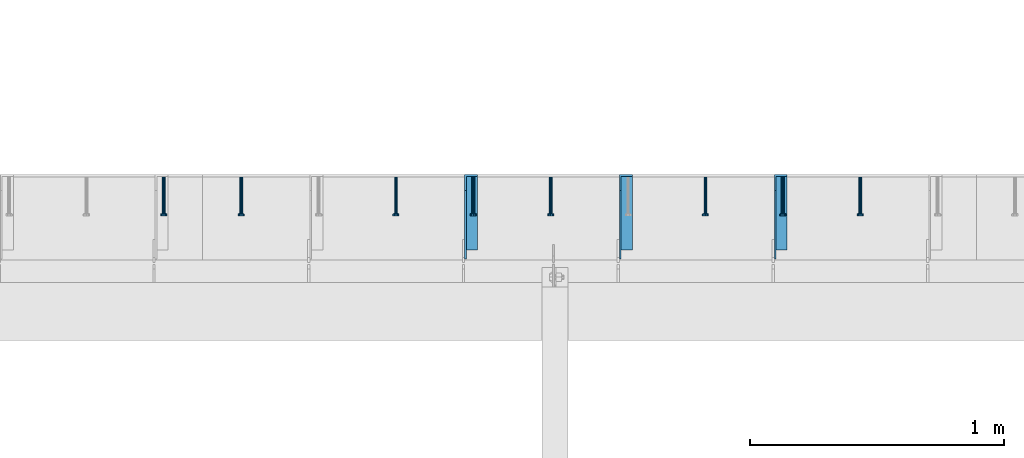
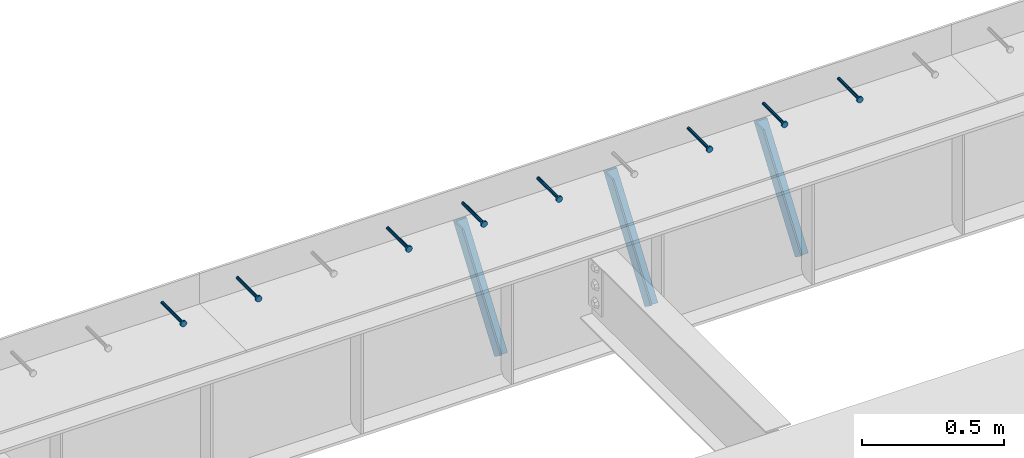
# One storey, part 1339 of 1763: 8 beams, 3 members, 9 elements without a shape of their own.
"""IFC2X3 building model written with IfcOpenShell, lengths in millimetres."""

import ifcopenshell
import ifcopenshell.guid

model = None  # the IFC model being written
_history = None  # IfcOwnerHistory: only IFC2X3 demands one
_inside = {}  # id of a spatial element -> (the spatial element, [elements in it])
_under = {}  # id of a project, library or spatial element -> (it, [spatial elements below it])
_declared = {}  # id of a project -> (the project, [libraries it declares])
_typed = {}  # id of a type object -> (the type object, [elements of that type])
_made_of = {}  # id of a material, layer set ... -> (it, [elements and type objects made of it])


def new_model(schema):
    """Start an empty IFC model of exactly this schema.

    Asked for "IFC4X3", IfcOpenShell would pick the latest addendum, in which some entities
    have other attributes; the version numbers below select the first issue.
    IFC2X3 requires an IfcOwnerHistory on every rooted entity: one is made here for all.
    """
    global model, _history
    if schema == "IFC4X3":
        model = ifcopenshell.file(schema_version=(4, 3, 0, 0))
    else:
        model = ifcopenshell.file(schema=schema)
    _inside.clear()
    _under.clear()
    _declared.clear()
    _typed.clear()
    _made_of.clear()
    _history = None
    if model.schema == "IFC2X3":
        org = make("IfcOrganization", Name="unknown")
        user = make(
            "IfcPersonAndOrganization",
            ThePerson=make("IfcPerson", FamilyName="unknown"),
            TheOrganization=org,
        )
        app = make(
            "IfcApplication",
            ApplicationDeveloper=org,
            Version="unknown",
            ApplicationFullName="unknown",
            ApplicationIdentifier="unknown",
        )
        _history = make(
            "IfcOwnerHistory",
            OwningUser=user,
            OwningApplication=app,
            ChangeAction="ADDED",
            CreationDate=0,
        )
    return model


def make(cls, **values):
    """One entity of the class cls with the attributes given. An attribute that is None is left unset."""
    return model.create_entity(
        cls, **{name: value for name, value in values.items() if value is not None}
    )


def rooted(cls, **values):
    """An entity with a GlobalId (a new one), such as an element, a storey or a relation."""
    return make(cls, GlobalId=ifcopenshell.guid.new(), OwnerHistory=_history, **values)


def si_unit(unit_type, name, prefix=None):
    """IfcSIUnit, for example si_unit("LENGTHUNIT", "METRE", prefix="MILLI")."""
    return make("IfcSIUnit", UnitType=unit_type, Prefix=prefix, Name=name)


def assignment(units):
    """IfcUnitAssignment: the units of a project."""
    return None if units is None else make("IfcUnitAssignment", Units=units)


def point(xyz):
    """IfcCartesianPoint."""
    return None if xyz is None else make("IfcCartesianPoint", Coordinates=xyz)


def direction(xyz):
    """IfcDirection."""
    return None if xyz is None else make("IfcDirection", DirectionRatios=xyz)


def frame(location, z_axis=None, x_axis=None):
    """IfcAxis2Placement3D, a coordinate frame: its origin and axes. An axis left out is left unset."""
    return make(
        "IfcAxis2Placement3D",
        Location=point(location),
        Axis=direction(z_axis),
        RefDirection=direction(x_axis),
    )


def origin_with_axes():
    """The frame at (0, 0, 0) with the z axis (0, 0, 1) and the x axis (1, 0, 0) written out."""
    return frame((0.0, 0.0, 0.0), z_axis=(0.0, 0.0, 1.0), x_axis=(1.0, 0.0, 0.0))


def place(relative_to, where):
    """IfcLocalPlacement: puts the frame where relative to a parent placement (None: the world)."""
    return make(
        "IfcLocalPlacement", PlacementRelTo=relative_to, RelativePlacement=where
    )


def context(
    kind, dimensions, precision=None, world=None, true_north=None, identifier=None
):
    """IfcGeometricRepresentationContext, for example the 3D "Model" context."""
    return make(
        "IfcGeometricRepresentationContext",
        ContextIdentifier=identifier,
        ContextType=kind,
        CoordinateSpaceDimension=dimensions,
        Precision=precision,
        WorldCoordinateSystem=world,
        TrueNorth=true_north,
    )


def subcontext(parent, identifier, kind, view, scale=None):
    """IfcGeometricRepresentationSubContext, for example "Body" below "Model"."""
    return make(
        "IfcGeometricRepresentationSubContext",
        ContextIdentifier=identifier,
        ContextType=kind,
        ParentContext=parent,
        TargetScale=scale,
        TargetView=view,
    )


def project(units=None, contexts=None):
    """IfcProject with its units and contexts."""
    return rooted(
        "IfcProject",
        Name="project",
        RepresentationContexts=contexts,
        UnitsInContext=assignment(units),
    )


def spatial(cls, under=None, at=None, **own):
    """A site, building, storey or space (cls), placed at a placement, below another one or the project."""
    s = rooted(cls, ObjectPlacement=at, **own)
    if under is not None:
        _under.setdefault(under.id(), (under, []))[1].append(s)
    return s


def faces_of(points, faces, orient=None, outer=None):
    """IfcFace entities. A face is a list of loops; a loop is a list of indices into points, from 0.

    orient and outer hold one flag for each loop. By default every Orientation is true, the
    first loop of a face is its IfcFaceOuterBound and the others are IfcFaceBound.
    """
    made = []
    for i, loops in enumerate(faces):
        bounds = []
        for j, loop in enumerate(loops):
            is_outer = j == 0 if outer is None else outer[i][j]
            bounds.append(
                make(
                    "IfcFaceOuterBound" if is_outer else "IfcFaceBound",
                    Bound=make("IfcPolyLoop", Polygon=[points[k] for k in loop]),
                    Orientation=True if orient is None else orient[i][j],
                )
            )
        made.append(make("IfcFace", Bounds=bounds))
    return made


def faceted_brep(points, faces, orient=None, outer=None, voids=None):
    """IfcFacetedBrep: a solid bounded by flat faces; with voids (closed shells), ...WithVoids."""
    shared = [point(p) for p in points]
    hull = make("IfcClosedShell", CfsFaces=faces_of(shared, faces, orient, outer))
    if voids is None:
        return make("IfcFacetedBrep", Outer=hull)
    return make(
        "IfcFacetedBrepWithVoids",
        Outer=hull,
        Voids=[
            make(cls, CfsFaces=faces_of(shared, fs, o, b)) for cls, fs, o, b in voids
        ],
    )


def shape(context_of_items, identifier, shape_type, items):
    """IfcShapeRepresentation: the items that make up one representation, for example the "Body"."""
    return make(
        "IfcShapeRepresentation",
        ContextOfItems=context_of_items,
        RepresentationIdentifier=identifier,
        RepresentationType=shape_type,
        Items=items,
    )


def material(Name=None, Category=None):
    """IfcMaterial."""
    return make("IfcMaterial", Name=Name, Category=Category)


def made_of(thing, what):
    """Note that an element or type object is made of a material, layer set ...; save() writes the relation."""
    if what is not None:
        _made_of.setdefault(what.id(), (what, []))[1].append(thing)
    return thing


def type_object(cls, material=None, **own):
    """A type object (cls), such as IfcWallType, which elements share."""
    return made_of(rooted(cls, **own), material)


def element(
    cls,
    number,
    at=None,
    inside=None,
    cuts=None,
    type_object=None,
    material=None,
    context=None,
    identifier="Body",
    shape_type=None,
    held_by="IfcProductDefinitionShape",
    body=None,
    shapes=None,
    **own,
):
    """One element of the class cls, such as IfcWall. Its Tag is "e" and its number.

    at: its placement. inside: the storey or other place that contains it. cuts: it is an
    opening in that element (IfcRelVoidsElement). A single representation is given by context,
    identifier, shape_type and body (its items); several are given by shapes. held_by: the class
    of the entity that holds the representations. save() writes the other relations.
    """
    e = rooted(cls, Tag="e%d" % number, ObjectPlacement=at, **own)
    if body is not None:
        shapes = [shape(context, identifier, shape_type, body)]
    if shapes is not None:
        e.Representation = make(held_by, Representations=shapes)
    if inside is not None:
        _inside.setdefault(inside.id(), (inside, []))[1].append(e)
    if cuts is not None:
        rooted(
            "IfcRelVoidsElement", RelatingBuildingElement=cuts, RelatedOpeningElement=e
        )
    if type_object is not None:
        _typed.setdefault(type_object.id(), (type_object, []))[1].append(e)
    return made_of(e, material)


def aggregate(whole, parts):
    """IfcRelAggregates: a whole, such as a stair, and the parts it consists of."""
    return rooted("IfcRelAggregates", RelatingObject=whole, RelatedObjects=parts)


def save(model, path):
    """Write the relations noted so far, then the file.

    IfcRelAggregates (storeys below a building ...), IfcRelContainedInSpatialStructure (elements
    in a storey), IfcRelDefinesByType, IfcRelAssociatesMaterial and IfcRelDeclares: one each for
    every whole, place, type object, material and project.
    """
    for whole, parts in _under.values():
        aggregate(whole, parts)
    for where, things in _inside.values():
        rooted(
            "IfcRelContainedInSpatialStructure",
            RelatedElements=things,
            RelatingStructure=where,
        )
    for kind, things in _typed.values():
        rooted("IfcRelDefinesByType", RelatedObjects=things, RelatingType=kind)
    for what, things in _made_of.values():
        rooted("IfcRelAssociatesMaterial", RelatedObjects=things, RelatingMaterial=what)
    for by, libraries in _declared.values():
        rooted("IfcRelDeclares", RelatingContext=by, RelatedDefinitions=libraries)
    model.write(path)


model = new_model("IFC2X3")

# Units and contexts
model_context = context("Model", 3, precision=1e-05, world=origin_with_axes())
body_context = subcontext(model_context, "Body", "Model", "MODEL_VIEW")
ifc_project = project(units=[si_unit("LENGTHUNIT", "METRE", prefix="MILLI"), si_unit("AREAUNIT", "SQUARE_METRE"), si_unit("VOLUMEUNIT", "CUBIC_METRE"), si_unit("MASSUNIT", "GRAM", prefix="KILO"), si_unit("TIMEUNIT", "SECOND"), si_unit("PLANEANGLEUNIT", "RADIAN"), si_unit("SOLIDANGLEUNIT", "STERADIAN"), si_unit("THERMODYNAMICTEMPERATUREUNIT", "DEGREE_CELSIUS"), si_unit("LUMINOUSINTENSITYUNIT", "LUMEN")], contexts=[model_context])

# Site, building, storey
site_placement = place(None, origin_with_axes())
site = spatial("IfcSite", under=ifc_project, at=site_placement, CompositionType="ELEMENT")
building_placement = place(site_placement, origin_with_axes())
building = spatial("IfcBuilding", under=site, at=building_placement, Name="Undefined", CompositionType="ELEMENT")
storey_placement = place(building_placement, origin_with_axes())
storey = spatial("IfcBuildingStorey", under=building, at=storey_placement, Name="Undefined", CompositionType="ELEMENT", Elevation=0.0)

# Assembly, beam
assembly_1_placement = place(storey_placement, origin_with_axes())
assembly_1 = element("IfcElementAssembly", 1, at=assembly_1_placement, inside=storey, Name="HEADED STUD ANCHOR", AssemblyPlace="NOTDEFINED", PredefinedType="RIGID_FRAME")
ifc_material_1 = material(Name="STEEL/A108")
beam_type = type_object("IfcBeamType", PredefinedType="NOTDEFINED")
beam_1_placement = place(assembly_1_placement, frame((-76250.2372736984, 53984.5250183106, 5264.23140606069), z_axis=(0.0, 0.0, 1.0), x_axis=(0.0, -1.0, 0.0)))
beam_1 = element("IfcBeam", 2, at=beam_1_placement, type_object=beam_type, material=ifc_material_1, Name="HEADED STUD ANCHOR", context=body_context, shape_type="Brep", body=[
    faceted_brep([(0.0, -3.1800000667572, 5.5), (0.0, -5.5, 3.1800000667572), (141.732000000002, -5.5, 3.1800000667572), (141.732000000002, -3.1800000667572, 5.5), (0.0, -6.34999999999491, 1.45519152283669e-11), (141.732000000002, -6.34999990463257, 0.0), (0.0, -5.5, -3.1800000667572), (141.732000000002, -5.5, -3.1800000667572), (0.0, -3.1800000667572, -5.5), (141.732000000002, -3.1800000667572, -5.5), (0.0, 0.0, -6.34999990463257), (141.732000000002, 0.0, -6.34999990463257), (0.0, 3.1800000667572, -5.5), (141.732000000002, 3.1800000667572, -5.5), (0.0, 5.5, -3.1800000667572), (141.732000000002, 5.5, -3.1800000667572), (0.0, 6.34999999999491, -2.91038304567337e-11), (141.732000000002, 6.34999990463257, 0.0), (0.0, 5.5, 3.1800000667572), (141.732000000002, 5.5, 3.1800000667572), (0.0, 3.1800000667572, 5.5), (141.732000000002, 3.1800000667572, 5.5), (0.0, 0.0, 6.34999990463257), (141.732000000002, 0.0, 6.34999990463257), (144.780000000001, -10.9899997711182, 6.34999990463257), (144.780000000001, -6.34000015258789, 10.9899997711182), (144.780000000001, -12.6999998092651, 0.0), (144.780000000001, -10.9899997711182, -6.34999990463257), (144.780000000001, -6.34000015258789, -10.9899997711182), (144.780000000001, 0.0, -12.6899995803833), (144.780000000001, 6.34000015258789, -10.9899997711182), (144.780000000001, 10.9899997711182, -6.34999990463257), (144.780000000001, 12.6999998092651, 0.0), (144.780000000001, 10.9899997711182, 6.34999990463257), (144.780000000001, 6.34000015258789, 10.9899997711182), (144.780000000001, 0.0, 12.6899995803833), (152.400000000001, -10.9899997711182, 6.34999990463257), (152.400000000001, -6.34000015258789, 10.9899997711182), (152.400000000001, -12.6999998092651, 0.0), (152.400000000001, -10.9899997711182, -6.34999990463257), (152.400000000001, -6.34000015258789, -10.9899997711182), (152.400000000001, 0.0, -12.6899995803833), (152.400000000001, 6.34000015258789, -10.9899997711182), (152.400000000001, 10.9899997711182, -6.34999990463257), (152.400000000001, 12.6999998092651, 0.0), (152.400000000001, 10.9899997711182, 6.34999990463257), (152.400000000001, 6.34000015258789, 10.9899997711182), (152.400000000001, 0.0, 12.6899995803833)], [[[0, 1, 2, 3]], [[1, 4, 5, 2]], [[4, 6, 7, 5]], [[6, 8, 9, 7]], [[8, 10, 11, 9]], [[10, 12, 13, 11]], [[12, 14, 15, 13]], [[14, 16, 17, 15]], [[16, 18, 19, 17]], [[18, 20, 21, 19]], [[20, 22, 23, 21]], [[22, 0, 3, 23]], [[22, 20, 18, 16, 14, 12, 10, 8, 6, 4, 1, 0]], [[3, 2, 24, 25]], [[2, 5, 26, 24]], [[5, 7, 27, 26]], [[7, 9, 28, 27]], [[9, 11, 29, 28]], [[11, 13, 30, 29]], [[13, 15, 31, 30]], [[15, 17, 32, 31]], [[17, 19, 33, 32]], [[19, 21, 34, 33]], [[21, 23, 35, 34]], [[23, 3, 25, 35]], [[25, 24, 36, 37]], [[24, 26, 38, 36]], [[26, 27, 39, 38]], [[27, 28, 40, 39]], [[28, 29, 41, 40]], [[29, 30, 42, 41]], [[30, 31, 43, 42]], [[31, 32, 44, 43]], [[32, 33, 45, 44]], [[33, 34, 46, 45]], [[34, 35, 47, 46]], [[35, 25, 37, 47]], [[38, 39, 40, 41, 42, 43, 44, 45, 46, 47, 37, 36]]]),
])
aggregate(assembly_1, [beam_1])

assembly_2_placement = place(storey_placement, origin_with_axes())
assembly_2 = element("IfcElementAssembly", 3, at=assembly_2_placement, inside=storey, Name="HEADED STUD ANCHOR", AssemblyPlace="NOTDEFINED", PredefinedType="RIGID_FRAME")
beam_2_placement = place(assembly_2_placement, frame((-76555.0372736983, 53984.5250183106, 5264.23140606069), z_axis=(0.0, 0.0, 1.0), x_axis=(0.0, -1.0, 0.0)))
beam_2 = element("IfcBeam", 4, at=beam_2_placement, type_object=beam_type, material=ifc_material_1, Name="HEADED STUD ANCHOR", context=body_context, shape_type="Brep", body=[
    faceted_brep([(0.0, -3.1800000667572, 5.5), (0.0, -5.5, 3.1800000667572), (141.732000000002, -5.5, 3.1800000667572), (141.732000000002, -3.1800000667572, 5.5), (0.0, -6.34999999999491, 1.45519152283669e-11), (141.732000000002, -6.34999990463257, 0.0), (0.0, -5.5, -3.1800000667572), (141.732000000002, -5.5, -3.1800000667572), (0.0, -3.1800000667572, -5.5), (141.732000000002, -3.1800000667572, -5.5), (0.0, 0.0, -6.34999990463257), (141.732000000002, 0.0, -6.34999990463257), (0.0, 3.1800000667572, -5.5), (141.732000000002, 3.1800000667572, -5.5), (0.0, 5.5, -3.1800000667572), (141.732000000002, 5.5, -3.1800000667572), (0.0, 6.34999999999491, -2.91038304567337e-11), (141.732000000002, 6.34999990463257, 0.0), (0.0, 5.5, 3.1800000667572), (141.732000000002, 5.5, 3.1800000667572), (0.0, 3.1800000667572, 5.5), (141.732000000002, 3.1800000667572, 5.5), (0.0, 0.0, 6.34999990463257), (141.732000000002, 0.0, 6.34999990463257), (144.780000000001, -10.9899997711182, 6.34999990463257), (144.780000000001, -6.34000015258789, 10.9899997711182), (144.780000000001, -12.6999998092651, 0.0), (144.780000000001, -10.9899997711182, -6.34999990463257), (144.780000000001, -6.34000015258789, -10.9899997711182), (144.780000000001, 0.0, -12.6899995803833), (144.780000000001, 6.34000015258789, -10.9899997711182), (144.780000000001, 10.9899997711182, -6.34999990463257), (144.780000000001, 12.6999998092651, 0.0), (144.780000000001, 10.9899997711182, 6.34999990463257), (144.780000000001, 6.34000015258789, 10.9899997711182), (144.780000000001, 0.0, 12.6899995803833), (152.400000000001, -10.9899997711182, 6.34999990463257), (152.400000000001, -6.34000015258789, 10.9899997711182), (152.400000000001, -12.6999998092651, 0.0), (152.400000000001, -10.9899997711182, -6.34999990463257), (152.400000000001, -6.34000015258789, -10.9899997711182), (152.400000000001, 0.0, -12.6899995803833), (152.400000000001, 6.34000015258789, -10.9899997711182), (152.400000000001, 10.9899997711182, -6.34999990463257), (152.400000000001, 12.6999998092651, 0.0), (152.400000000001, 10.9899997711182, 6.34999990463257), (152.400000000001, 6.34000015258789, 10.9899997711182), (152.400000000001, 0.0, 12.6899995803833)], [[[0, 1, 2, 3]], [[1, 4, 5, 2]], [[4, 6, 7, 5]], [[6, 8, 9, 7]], [[8, 10, 11, 9]], [[10, 12, 13, 11]], [[12, 14, 15, 13]], [[14, 16, 17, 15]], [[16, 18, 19, 17]], [[18, 20, 21, 19]], [[20, 22, 23, 21]], [[22, 0, 3, 23]], [[22, 20, 18, 16, 14, 12, 10, 8, 6, 4, 1, 0]], [[3, 2, 24, 25]], [[2, 5, 26, 24]], [[5, 7, 27, 26]], [[7, 9, 28, 27]], [[9, 11, 29, 28]], [[11, 13, 30, 29]], [[13, 15, 31, 30]], [[15, 17, 32, 31]], [[17, 19, 33, 32]], [[19, 21, 34, 33]], [[21, 23, 35, 34]], [[23, 3, 25, 35]], [[25, 24, 36, 37]], [[24, 26, 38, 36]], [[26, 27, 39, 38]], [[27, 28, 40, 39]], [[28, 29, 41, 40]], [[29, 30, 42, 41]], [[30, 31, 43, 42]], [[31, 32, 44, 43]], [[32, 33, 45, 44]], [[33, 34, 46, 45]], [[34, 35, 47, 46]], [[35, 25, 37, 47]], [[38, 39, 40, 41, 42, 43, 44, 45, 46, 47, 37, 36]]]),
])
aggregate(assembly_2, [beam_2])

assembly_3_placement = place(storey_placement, origin_with_axes())
assembly_3 = element("IfcElementAssembly", 5, at=assembly_3_placement, inside=storey, Name="HEADED STUD ANCHOR", AssemblyPlace="NOTDEFINED", PredefinedType="RIGID_FRAME")
beam_3_placement = place(assembly_3_placement, frame((-76859.8372736983, 53984.5250183106, 5264.23140606069), z_axis=(0.0, 0.0, 1.0), x_axis=(0.0, -1.0, 0.0)))
beam_3 = element("IfcBeam", 6, at=beam_3_placement, type_object=beam_type, material=ifc_material_1, Name="HEADED STUD ANCHOR", context=body_context, shape_type="Brep", body=[
    faceted_brep([(0.0, -3.1800000667572, 5.5), (0.0, -5.5, 3.1800000667572), (141.732000000002, -5.5, 3.1800000667572), (141.732000000002, -3.1800000667572, 5.5), (0.0, -6.34999999999491, 1.45519152283669e-11), (141.732000000002, -6.34999990463257, 0.0), (0.0, -5.5, -3.1800000667572), (141.732000000002, -5.5, -3.1800000667572), (0.0, -3.1800000667572, -5.5), (141.732000000002, -3.1800000667572, -5.5), (0.0, 0.0, -6.34999990463257), (141.732000000002, 0.0, -6.34999990463257), (0.0, 3.1800000667572, -5.5), (141.732000000002, 3.1800000667572, -5.5), (0.0, 5.5, -3.1800000667572), (141.732000000002, 5.5, -3.1800000667572), (0.0, 6.34999999999491, -2.91038304567337e-11), (141.732000000002, 6.34999990463257, 0.0), (0.0, 5.5, 3.1800000667572), (141.732000000002, 5.5, 3.1800000667572), (0.0, 3.1800000667572, 5.5), (141.732000000002, 3.1800000667572, 5.5), (0.0, 0.0, 6.34999990463257), (141.732000000002, 0.0, 6.34999990463257), (144.780000000001, -10.9899997711182, 6.34999990463257), (144.780000000001, -6.34000015258789, 10.9899997711182), (144.780000000001, -12.6999998092651, 0.0), (144.780000000001, -10.9899997711182, -6.34999990463257), (144.780000000001, -6.34000015258789, -10.9899997711182), (144.780000000001, 0.0, -12.6899995803833), (144.780000000001, 6.34000015258789, -10.9899997711182), (144.780000000001, 10.9899997711182, -6.34999990463257), (144.780000000001, 12.6999998092651, 0.0), (144.780000000001, 10.9899997711182, 6.34999990463257), (144.780000000001, 6.34000015258789, 10.9899997711182), (144.780000000001, 0.0, 12.6899995803833), (152.400000000001, -10.9899997711182, 6.34999990463257), (152.400000000001, -6.34000015258789, 10.9899997711182), (152.400000000001, -12.6999998092651, 0.0), (152.400000000001, -10.9899997711182, -6.34999990463257), (152.400000000001, -6.34000015258789, -10.9899997711182), (152.400000000001, 0.0, -12.6899995803833), (152.400000000001, 6.34000015258789, -10.9899997711182), (152.400000000001, 10.9899997711182, -6.34999990463257), (152.400000000001, 12.6999998092651, 0.0), (152.400000000001, 10.9899997711182, 6.34999990463257), (152.400000000001, 6.34000015258789, 10.9899997711182), (152.400000000001, 0.0, 12.6899995803833)], [[[0, 1, 2, 3]], [[1, 4, 5, 2]], [[4, 6, 7, 5]], [[6, 8, 9, 7]], [[8, 10, 11, 9]], [[10, 12, 13, 11]], [[12, 14, 15, 13]], [[14, 16, 17, 15]], [[16, 18, 19, 17]], [[18, 20, 21, 19]], [[20, 22, 23, 21]], [[22, 0, 3, 23]], [[22, 20, 18, 16, 14, 12, 10, 8, 6, 4, 1, 0]], [[3, 2, 24, 25]], [[2, 5, 26, 24]], [[5, 7, 27, 26]], [[7, 9, 28, 27]], [[9, 11, 29, 28]], [[11, 13, 30, 29]], [[13, 15, 31, 30]], [[15, 17, 32, 31]], [[17, 19, 33, 32]], [[19, 21, 34, 33]], [[21, 23, 35, 34]], [[23, 3, 25, 35]], [[25, 24, 36, 37]], [[24, 26, 38, 36]], [[26, 27, 39, 38]], [[27, 28, 40, 39]], [[28, 29, 41, 40]], [[29, 30, 42, 41]], [[30, 31, 43, 42]], [[31, 32, 44, 43]], [[32, 33, 45, 44]], [[33, 34, 46, 45]], [[34, 35, 47, 46]], [[35, 25, 37, 47]], [[38, 39, 40, 41, 42, 43, 44, 45, 46, 47, 37, 36]]]),
])
aggregate(assembly_3, [beam_3])

assembly_4_placement = place(storey_placement, origin_with_axes())
assembly_4 = element("IfcElementAssembly", 7, at=assembly_4_placement, inside=storey, Name="HEADED STUD ANCHOR", AssemblyPlace="NOTDEFINED", PredefinedType="RIGID_FRAME")
beam_4_placement = place(assembly_4_placement, frame((-77469.4372736983, 53984.5250183106, 5264.23140606069), z_axis=(0.0, 0.0, 1.0), x_axis=(0.0, -1.0, 0.0)))
beam_4 = element("IfcBeam", 8, at=beam_4_placement, type_object=beam_type, material=ifc_material_1, Name="HEADED STUD ANCHOR", context=body_context, shape_type="Brep", body=[
    faceted_brep([(0.0, -3.1800000667572, 5.5), (0.0, -5.5, 3.1800000667572), (141.732000000002, -5.5, 3.1800000667572), (141.732000000002, -3.1800000667572, 5.5), (0.0, -6.34999999999491, 1.45519152283669e-11), (141.732000000002, -6.34999990463257, 0.0), (0.0, -5.5, -3.1800000667572), (141.732000000002, -5.5, -3.1800000667572), (0.0, -3.1800000667572, -5.5), (141.732000000002, -3.1800000667572, -5.5), (0.0, 0.0, -6.34999990463257), (141.732000000002, 0.0, -6.34999990463257), (0.0, 3.1800000667572, -5.5), (141.732000000002, 3.1800000667572, -5.5), (0.0, 5.5, -3.1800000667572), (141.732000000002, 5.5, -3.1800000667572), (0.0, 6.34999999999491, -2.91038304567337e-11), (141.732000000002, 6.34999990463257, 0.0), (0.0, 5.5, 3.1800000667572), (141.732000000002, 5.5, 3.1800000667572), (0.0, 3.1800000667572, 5.5), (141.732000000002, 3.1800000667572, 5.5), (0.0, 0.0, 6.34999990463257), (141.732000000002, 0.0, 6.34999990463257), (144.780000000001, -10.9899997711182, 6.34999990463257), (144.780000000001, -6.34000015258789, 10.9899997711182), (144.780000000001, -12.6999998092651, 0.0), (144.780000000001, -10.9899997711182, -6.34999990463257), (144.780000000001, -6.34000015258789, -10.9899997711182), (144.780000000001, 0.0, -12.6899995803833), (144.780000000001, 6.34000015258789, -10.9899997711182), (144.780000000001, 10.9899997711182, -6.34999990463257), (144.780000000001, 12.6999998092651, 0.0), (144.780000000001, 10.9899997711182, 6.34999990463257), (144.780000000001, 6.34000015258789, 10.9899997711182), (144.780000000001, 0.0, 12.6899995803833), (152.400000000001, -10.9899997711182, 6.34999990463257), (152.400000000001, -6.34000015258789, 10.9899997711182), (152.400000000001, -12.6999998092651, 0.0), (152.400000000001, -10.9899997711182, -6.34999990463257), (152.400000000001, -6.34000015258789, -10.9899997711182), (152.400000000001, 0.0, -12.6899995803833), (152.400000000001, 6.34000015258789, -10.9899997711182), (152.400000000001, 10.9899997711182, -6.34999990463257), (152.400000000001, 12.6999998092651, 0.0), (152.400000000001, 10.9899997711182, 6.34999990463257), (152.400000000001, 6.34000015258789, 10.9899997711182), (152.400000000001, 0.0, 12.6899995803833)], [[[0, 1, 2, 3]], [[1, 4, 5, 2]], [[4, 6, 7, 5]], [[6, 8, 9, 7]], [[8, 10, 11, 9]], [[10, 12, 13, 11]], [[12, 14, 15, 13]], [[14, 16, 17, 15]], [[16, 18, 19, 17]], [[18, 20, 21, 19]], [[20, 22, 23, 21]], [[22, 0, 3, 23]], [[22, 20, 18, 16, 14, 12, 10, 8, 6, 4, 1, 0]], [[3, 2, 24, 25]], [[2, 5, 26, 24]], [[5, 7, 27, 26]], [[7, 9, 28, 27]], [[9, 11, 29, 28]], [[11, 13, 30, 29]], [[13, 15, 31, 30]], [[15, 17, 32, 31]], [[17, 19, 33, 32]], [[19, 21, 34, 33]], [[21, 23, 35, 34]], [[23, 3, 25, 35]], [[25, 24, 36, 37]], [[24, 26, 38, 36]], [[26, 27, 39, 38]], [[27, 28, 40, 39]], [[28, 29, 41, 40]], [[29, 30, 42, 41]], [[30, 31, 43, 42]], [[31, 32, 44, 43]], [[32, 33, 45, 44]], [[33, 34, 46, 45]], [[34, 35, 47, 46]], [[35, 25, 37, 47]], [[38, 39, 40, 41, 42, 43, 44, 45, 46, 47, 37, 36]]]),
])
aggregate(assembly_4, [beam_4])

assembly_5_placement = place(storey_placement, origin_with_axes())
assembly_5 = element("IfcElementAssembly", 9, at=assembly_5_placement, inside=storey, Name="HEADED STUD ANCHOR", AssemblyPlace="NOTDEFINED", PredefinedType="RIGID_FRAME")
beam_5_placement = place(assembly_5_placement, frame((-77774.2372736984, 53984.5250183106, 5264.23140606069), z_axis=(0.0, 0.0, 1.0), x_axis=(0.0, -1.0, 0.0)))
beam_5 = element("IfcBeam", 10, at=beam_5_placement, type_object=beam_type, material=ifc_material_1, Name="HEADED STUD ANCHOR", context=body_context, shape_type="Brep", body=[
    faceted_brep([(0.0, -3.1800000667572, 5.5), (0.0, -5.5, 3.1800000667572), (141.732000000002, -5.5, 3.1800000667572), (141.732000000002, -3.1800000667572, 5.5), (0.0, -6.34999999999491, 1.45519152283669e-11), (141.732000000002, -6.34999990463257, 0.0), (0.0, -5.5, -3.1800000667572), (141.732000000002, -5.5, -3.1800000667572), (0.0, -3.1800000667572, -5.5), (141.732000000002, -3.1800000667572, -5.5), (0.0, 0.0, -6.34999990463257), (141.732000000002, 0.0, -6.34999990463257), (0.0, 3.1800000667572, -5.5), (141.732000000002, 3.1800000667572, -5.5), (0.0, 5.5, -3.1800000667572), (141.732000000002, 5.5, -3.1800000667572), (0.0, 6.34999999999491, -2.91038304567337e-11), (141.732000000002, 6.34999990463257, 0.0), (0.0, 5.5, 3.1800000667572), (141.732000000002, 5.5, 3.1800000667572), (0.0, 3.1800000667572, 5.5), (141.732000000002, 3.1800000667572, 5.5), (0.0, 0.0, 6.34999990463257), (141.732000000002, 0.0, 6.34999990463257), (144.780000000001, -10.9899997711182, 6.34999990463257), (144.780000000001, -6.34000015258789, 10.9899997711182), (144.780000000001, -12.6999998092651, 0.0), (144.780000000001, -10.9899997711182, -6.34999990463257), (144.780000000001, -6.34000015258789, -10.9899997711182), (144.780000000001, 0.0, -12.6899995803833), (144.780000000001, 6.34000015258789, -10.9899997711182), (144.780000000001, 10.9899997711182, -6.34999990463257), (144.780000000001, 12.6999998092651, 0.0), (144.780000000001, 10.9899997711182, 6.34999990463257), (144.780000000001, 6.34000015258789, 10.9899997711182), (144.780000000001, 0.0, 12.6899995803833), (152.400000000001, -10.9899997711182, 6.34999990463257), (152.400000000001, -6.34000015258789, 10.9899997711182), (152.400000000001, -12.6999998092651, 0.0), (152.400000000001, -10.9899997711182, -6.34999990463257), (152.400000000001, -6.34000015258789, -10.9899997711182), (152.400000000001, 0.0, -12.6899995803833), (152.400000000001, 6.34000015258789, -10.9899997711182), (152.400000000001, 10.9899997711182, -6.34999990463257), (152.400000000001, 12.6999998092651, 0.0), (152.400000000001, 10.9899997711182, 6.34999990463257), (152.400000000001, 6.34000015258789, 10.9899997711182), (152.400000000001, 0.0, 12.6899995803833)], [[[0, 1, 2, 3]], [[1, 4, 5, 2]], [[4, 6, 7, 5]], [[6, 8, 9, 7]], [[8, 10, 11, 9]], [[10, 12, 13, 11]], [[12, 14, 15, 13]], [[14, 16, 17, 15]], [[16, 18, 19, 17]], [[18, 20, 21, 19]], [[20, 22, 23, 21]], [[22, 0, 3, 23]], [[22, 20, 18, 16, 14, 12, 10, 8, 6, 4, 1, 0]], [[3, 2, 24, 25]], [[2, 5, 26, 24]], [[5, 7, 27, 26]], [[7, 9, 28, 27]], [[9, 11, 29, 28]], [[11, 13, 30, 29]], [[13, 15, 31, 30]], [[15, 17, 32, 31]], [[17, 19, 33, 32]], [[19, 21, 34, 33]], [[21, 23, 35, 34]], [[23, 3, 25, 35]], [[25, 24, 36, 37]], [[24, 26, 38, 36]], [[26, 27, 39, 38]], [[27, 28, 40, 39]], [[28, 29, 41, 40]], [[29, 30, 42, 41]], [[30, 31, 43, 42]], [[31, 32, 44, 43]], [[32, 33, 45, 44]], [[33, 34, 46, 45]], [[34, 35, 47, 46]], [[35, 25, 37, 47]], [[38, 39, 40, 41, 42, 43, 44, 45, 46, 47, 37, 36]]]),
])
aggregate(assembly_5, [beam_5])

assembly_6_placement = place(storey_placement, origin_with_axes())
assembly_6 = element("IfcElementAssembly", 11, at=assembly_6_placement, inside=storey, Name="HEADED STUD ANCHOR", AssemblyPlace="NOTDEFINED", PredefinedType="RIGID_FRAME")
beam_6_placement = place(assembly_6_placement, frame((-78079.0372736983, 53984.5250183106, 5264.23140606069), z_axis=(0.0, 0.0, 1.0), x_axis=(0.0, -1.0, 0.0)))
beam_6 = element("IfcBeam", 12, at=beam_6_placement, type_object=beam_type, material=ifc_material_1, Name="HEADED STUD ANCHOR", context=body_context, shape_type="Brep", body=[
    faceted_brep([(0.0, -3.1800000667572, 5.5), (0.0, -5.5, 3.1800000667572), (141.732000000002, -5.5, 3.1800000667572), (141.732000000002, -3.1800000667572, 5.5), (0.0, -6.34999999999491, 1.45519152283669e-11), (141.732000000002, -6.34999990463257, 0.0), (0.0, -5.5, -3.1800000667572), (141.732000000002, -5.5, -3.1800000667572), (0.0, -3.1800000667572, -5.5), (141.732000000002, -3.1800000667572, -5.5), (0.0, 0.0, -6.34999990463257), (141.732000000002, 0.0, -6.34999990463257), (0.0, 3.1800000667572, -5.5), (141.732000000002, 3.1800000667572, -5.5), (0.0, 5.5, -3.1800000667572), (141.732000000002, 5.5, -3.1800000667572), (0.0, 6.34999999999491, -2.91038304567337e-11), (141.732000000002, 6.34999990463257, 0.0), (0.0, 5.5, 3.1800000667572), (141.732000000002, 5.5, 3.1800000667572), (0.0, 3.1800000667572, 5.5), (141.732000000002, 3.1800000667572, 5.5), (0.0, 0.0, 6.34999990463257), (141.732000000002, 0.0, 6.34999990463257), (144.780000000001, -10.9899997711182, 6.34999990463257), (144.780000000001, -6.34000015258789, 10.9899997711182), (144.780000000001, -12.6999998092651, 0.0), (144.780000000001, -10.9899997711182, -6.34999990463257), (144.780000000001, -6.34000015258789, -10.9899997711182), (144.780000000001, 0.0, -12.6899995803833), (144.780000000001, 6.34000015258789, -10.9899997711182), (144.780000000001, 10.9899997711182, -6.34999990463257), (144.780000000001, 12.6999998092651, 0.0), (144.780000000001, 10.9899997711182, 6.34999990463257), (144.780000000001, 6.34000015258789, 10.9899997711182), (144.780000000001, 0.0, 12.6899995803833), (152.400000000001, -10.9899997711182, 6.34999990463257), (152.400000000001, -6.34000015258789, 10.9899997711182), (152.400000000001, -12.6999998092651, 0.0), (152.400000000001, -10.9899997711182, -6.34999990463257), (152.400000000001, -6.34000015258789, -10.9899997711182), (152.400000000001, 0.0, -12.6899995803833), (152.400000000001, 6.34000015258789, -10.9899997711182), (152.400000000001, 10.9899997711182, -6.34999990463257), (152.400000000001, 12.6999998092651, 0.0), (152.400000000001, 10.9899997711182, 6.34999990463257), (152.400000000001, 6.34000015258789, 10.9899997711182), (152.400000000001, 0.0, 12.6899995803833)], [[[0, 1, 2, 3]], [[1, 4, 5, 2]], [[4, 6, 7, 5]], [[6, 8, 9, 7]], [[8, 10, 11, 9]], [[10, 12, 13, 11]], [[12, 14, 15, 13]], [[14, 16, 17, 15]], [[16, 18, 19, 17]], [[18, 20, 21, 19]], [[20, 22, 23, 21]], [[22, 0, 3, 23]], [[22, 20, 18, 16, 14, 12, 10, 8, 6, 4, 1, 0]], [[3, 2, 24, 25]], [[2, 5, 26, 24]], [[5, 7, 27, 26]], [[7, 9, 28, 27]], [[9, 11, 29, 28]], [[11, 13, 30, 29]], [[13, 15, 31, 30]], [[15, 17, 32, 31]], [[17, 19, 33, 32]], [[19, 21, 34, 33]], [[21, 23, 35, 34]], [[23, 3, 25, 35]], [[25, 24, 36, 37]], [[24, 26, 38, 36]], [[26, 27, 39, 38]], [[27, 28, 40, 39]], [[28, 29, 41, 40]], [[29, 30, 42, 41]], [[30, 31, 43, 42]], [[31, 32, 44, 43]], [[32, 33, 45, 44]], [[33, 34, 46, 45]], [[34, 35, 47, 46]], [[35, 25, 37, 47]], [[38, 39, 40, 41, 42, 43, 44, 45, 46, 47, 37, 36]]]),
])
aggregate(assembly_6, [beam_6])

assembly_7_placement = place(storey_placement, origin_with_axes())
assembly_7 = element("IfcElementAssembly", 13, at=assembly_7_placement, inside=storey, Name="HEADED STUD ANCHOR", AssemblyPlace="NOTDEFINED", PredefinedType="RIGID_FRAME")
beam_7_placement = place(assembly_7_placement, frame((-78688.6372736983, 53984.5250183106, 5264.23140606069), z_axis=(0.0, 0.0, 1.0), x_axis=(0.0, -1.0, 0.0)))
beam_7 = element("IfcBeam", 14, at=beam_7_placement, type_object=beam_type, material=ifc_material_1, Name="HEADED STUD ANCHOR", context=body_context, shape_type="Brep", body=[
    faceted_brep([(0.0, -3.1800000667572, 5.5), (0.0, -5.5, 3.1800000667572), (141.732000000002, -5.5, 3.1800000667572), (141.732000000002, -3.1800000667572, 5.5), (0.0, -6.34999999999491, 1.45519152283669e-11), (141.732000000002, -6.34999990463257, 0.0), (0.0, -5.5, -3.1800000667572), (141.732000000002, -5.5, -3.1800000667572), (0.0, -3.1800000667572, -5.5), (141.732000000002, -3.1800000667572, -5.5), (0.0, 0.0, -6.34999990463257), (141.732000000002, 0.0, -6.34999990463257), (0.0, 3.1800000667572, -5.5), (141.732000000002, 3.1800000667572, -5.5), (0.0, 5.5, -3.1800000667572), (141.732000000002, 5.5, -3.1800000667572), (0.0, 6.34999999999491, -2.91038304567337e-11), (141.732000000002, 6.34999990463257, 0.0), (0.0, 5.5, 3.1800000667572), (141.732000000002, 5.5, 3.1800000667572), (0.0, 3.1800000667572, 5.5), (141.732000000002, 3.1800000667572, 5.5), (0.0, 0.0, 6.34999990463257), (141.732000000002, 0.0, 6.34999990463257), (144.780000000001, -10.9899997711182, 6.34999990463257), (144.780000000001, -6.34000015258789, 10.9899997711182), (144.780000000001, -12.6999998092651, 0.0), (144.780000000001, -10.9899997711182, -6.34999990463257), (144.780000000001, -6.34000015258789, -10.9899997711182), (144.780000000001, 0.0, -12.6899995803833), (144.780000000001, 6.34000015258789, -10.9899997711182), (144.780000000001, 10.9899997711182, -6.34999990463257), (144.780000000001, 12.6999998092651, 0.0), (144.780000000001, 10.9899997711182, 6.34999990463257), (144.780000000001, 6.34000015258789, 10.9899997711182), (144.780000000001, 0.0, 12.6899995803833), (152.400000000001, -10.9899997711182, 6.34999990463257), (152.400000000001, -6.34000015258789, 10.9899997711182), (152.400000000001, -12.6999998092651, 0.0), (152.400000000001, -10.9899997711182, -6.34999990463257), (152.400000000001, -6.34000015258789, -10.9899997711182), (152.400000000001, 0.0, -12.6899995803833), (152.400000000001, 6.34000015258789, -10.9899997711182), (152.400000000001, 10.9899997711182, -6.34999990463257), (152.400000000001, 12.6999998092651, 0.0), (152.400000000001, 10.9899997711182, 6.34999990463257), (152.400000000001, 6.34000015258789, 10.9899997711182), (152.400000000001, 0.0, 12.6899995803833)], [[[0, 1, 2, 3]], [[1, 4, 5, 2]], [[4, 6, 7, 5]], [[6, 8, 9, 7]], [[8, 10, 11, 9]], [[10, 12, 13, 11]], [[12, 14, 15, 13]], [[14, 16, 17, 15]], [[16, 18, 19, 17]], [[18, 20, 21, 19]], [[20, 22, 23, 21]], [[22, 0, 3, 23]], [[22, 20, 18, 16, 14, 12, 10, 8, 6, 4, 1, 0]], [[3, 2, 24, 25]], [[2, 5, 26, 24]], [[5, 7, 27, 26]], [[7, 9, 28, 27]], [[9, 11, 29, 28]], [[11, 13, 30, 29]], [[13, 15, 31, 30]], [[15, 17, 32, 31]], [[17, 19, 33, 32]], [[19, 21, 34, 33]], [[21, 23, 35, 34]], [[23, 3, 25, 35]], [[25, 24, 36, 37]], [[24, 26, 38, 36]], [[26, 27, 39, 38]], [[27, 28, 40, 39]], [[28, 29, 41, 40]], [[29, 30, 42, 41]], [[30, 31, 43, 42]], [[31, 32, 44, 43]], [[32, 33, 45, 44]], [[33, 34, 46, 45]], [[34, 35, 47, 46]], [[35, 25, 37, 47]], [[38, 39, 40, 41, 42, 43, 44, 45, 46, 47, 37, 36]]]),
])
aggregate(assembly_7, [beam_7])

assembly_8_placement = place(storey_placement, origin_with_axes())
assembly_8 = element("IfcElementAssembly", 15, at=assembly_8_placement, inside=storey, Name="HEADED STUD ANCHOR", AssemblyPlace="NOTDEFINED", PredefinedType="RIGID_FRAME")
beam_8_placement = place(assembly_8_placement, frame((-78993.4372736983, 53984.5250183106, 5264.23140606069), z_axis=(0.0, 0.0, 1.0), x_axis=(0.0, -1.0, 0.0)))
beam_8 = element("IfcBeam", 16, at=beam_8_placement, type_object=beam_type, material=ifc_material_1, Name="HEADED STUD ANCHOR", context=body_context, shape_type="Brep", body=[
    faceted_brep([(0.0, -3.1800000667572, 5.5), (0.0, -5.5, 3.1800000667572), (141.732000000002, -5.5, 3.1800000667572), (141.732000000002, -3.1800000667572, 5.5), (0.0, -6.34999999999491, 1.45519152283669e-11), (141.732000000002, -6.34999990463257, 0.0), (0.0, -5.5, -3.1800000667572), (141.732000000002, -5.5, -3.1800000667572), (0.0, -3.1800000667572, -5.5), (141.732000000002, -3.1800000667572, -5.5), (0.0, 0.0, -6.34999990463257), (141.732000000002, 0.0, -6.34999990463257), (0.0, 3.1800000667572, -5.5), (141.732000000002, 3.1800000667572, -5.5), (0.0, 5.5, -3.1800000667572), (141.732000000002, 5.5, -3.1800000667572), (0.0, 6.34999999999491, -2.91038304567337e-11), (141.732000000002, 6.34999990463257, 0.0), (0.0, 5.5, 3.1800000667572), (141.732000000002, 5.5, 3.1800000667572), (0.0, 3.1800000667572, 5.5), (141.732000000002, 3.1800000667572, 5.5), (0.0, 0.0, 6.34999990463257), (141.732000000002, 0.0, 6.34999990463257), (144.780000000001, -10.9899997711182, 6.34999990463257), (144.780000000001, -6.34000015258789, 10.9899997711182), (144.780000000001, -12.6999998092651, 0.0), (144.780000000001, -10.9899997711182, -6.34999990463257), (144.780000000001, -6.34000015258789, -10.9899997711182), (144.780000000001, 0.0, -12.6899995803833), (144.780000000001, 6.34000015258789, -10.9899997711182), (144.780000000001, 10.9899997711182, -6.34999990463257), (144.780000000001, 12.6999998092651, 0.0), (144.780000000001, 10.9899997711182, 6.34999990463257), (144.780000000001, 6.34000015258789, 10.9899997711182), (144.780000000001, 0.0, 12.6899995803833), (152.400000000001, -10.9899997711182, 6.34999990463257), (152.400000000001, -6.34000015258789, 10.9899997711182), (152.400000000001, -12.6999998092651, 0.0), (152.400000000001, -10.9899997711182, -6.34999990463257), (152.400000000001, -6.34000015258789, -10.9899997711182), (152.400000000001, 0.0, -12.6899995803833), (152.400000000001, 6.34000015258789, -10.9899997711182), (152.400000000001, 10.9899997711182, -6.34999990463257), (152.400000000001, 12.6999998092651, 0.0), (152.400000000001, 10.9899997711182, 6.34999990463257), (152.400000000001, 6.34000015258789, 10.9899997711182), (152.400000000001, 0.0, 12.6899995803833)], [[[0, 1, 2, 3]], [[1, 4, 5, 2]], [[4, 6, 7, 5]], [[6, 8, 9, 7]], [[8, 10, 11, 9]], [[10, 12, 13, 11]], [[12, 14, 15, 13]], [[14, 16, 17, 15]], [[16, 18, 19, 17]], [[18, 20, 21, 19]], [[20, 22, 23, 21]], [[22, 0, 3, 23]], [[22, 20, 18, 16, 14, 12, 10, 8, 6, 4, 1, 0]], [[3, 2, 24, 25]], [[2, 5, 26, 24]], [[5, 7, 27, 26]], [[7, 9, 28, 27]], [[9, 11, 29, 28]], [[11, 13, 30, 29]], [[13, 15, 31, 30]], [[15, 17, 32, 31]], [[17, 19, 33, 32]], [[19, 21, 34, 33]], [[21, 23, 35, 34]], [[23, 3, 25, 35]], [[25, 24, 36, 37]], [[24, 26, 38, 36]], [[26, 27, 39, 38]], [[27, 28, 40, 39]], [[28, 29, 41, 40]], [[29, 30, 42, 41]], [[30, 31, 43, 42]], [[31, 32, 44, 43]], [[32, 33, 45, 44]], [[33, 34, 46, 45]], [[34, 35, 47, 46]], [[35, 25, 37, 47]], [[38, 39, 40, 41, 42, 43, 44, 45, 46, 47, 37, 36]]]),
])
aggregate(assembly_8, [beam_8])

# Assembly, members
assembly_9_placement = place(storey_placement, origin_with_axes())
assembly_9 = element("IfcElementAssembly", 17, at=assembly_9_placement, inside=storey, Name="BEAM", AssemblyPlace="NOTDEFINED", PredefinedType="RIGID_FRAME")
ifc_material_2 = material(Name="STEEL/A36")
member_type = type_object("IfcMemberType", Name="L2X2X1/4", PredefinedType="NOTDEFINED")
member_1_placement = place(assembly_9_placement, frame((-77172.9716486984, 53682.7083833994, 4801.55161052494), z_axis=(0.0, -0.814117947745209, 0.580699549818259), x_axis=(0.0, 0.58069954981826, 0.814117947745209)))
member_1 = element("IfcMember", 18, at=member_1_placement, type_object=member_type, material=ifc_material_2, Name="ANGLE", ObjectType="L2X2X1/4", context=body_context, shape_type="Brep", body=[
    faceted_brep([(-1.45519152283669e-11, 25.4000000000015, -25.3999999999869), (1.45519152283669e-11, 25.4000000000015, 25.3999999999796), (464.304493432646, 25.4000000000015, 25.3999999991429), (500.539460322936, 25.4000000000015, -25.4000000009546), (1.45519152283669e-11, 19.0499999999993, 25.3999999999796), (464.304493432646, 19.0500000000029, 25.3999999991429), (-7.27595761418343e-12, 19.0499999999993, -19.0499999999956), (496.010089461648, 19.0500000000029, -19.0500000009415), (-7.27595761418343e-12, -25.4000000000015, -19.0499999999956), (496.010089461648, -25.4000000000015, -19.0500000009415), (-1.45519152283669e-11, -25.4000000000015, -25.3999999999869), (500.539460322936, -25.4000000000015, -25.4000000009546)], [[[0, 1, 2, 3]], [[1, 4, 5, 2]], [[4, 6, 7, 5]], [[6, 8, 9, 7]], [[8, 10, 11, 9]], [[10, 0, 3, 11]], [[5, 7, 9, 11, 3, 2]], [[10, 8, 6, 4, 1, 0]]]),
])
member_2_placement = place(assembly_9_placement, frame((-76563.3716486984, 53682.7083833994, 4801.55161052494), z_axis=(0.0, -0.814117947745209, 0.580699549818259), x_axis=(0.0, 0.58069954981826, 0.814117947745209)))
member_2 = element("IfcMember", 19, at=member_2_placement, type_object=member_type, material=ifc_material_2, Name="ANGLE", ObjectType="L2X2X1/4", context=body_context, shape_type="Brep", body=[
    faceted_brep([(-1.45519152283669e-11, 25.4000000000015, -25.3999999999869), (1.45519152283669e-11, 25.4000000000015, 25.3999999999796), (464.304493432646, 25.4000000000015, 25.3999999991429), (500.539460322936, 25.4000000000015, -25.4000000009546), (1.45519152283669e-11, 19.0499999999993, 25.3999999999796), (464.304493432646, 19.0500000000029, 25.3999999991429), (-7.27595761418343e-12, 19.0499999999993, -19.0499999999956), (496.010089461648, 19.0500000000029, -19.0500000009415), (-7.27595761418343e-12, -25.4000000000015, -19.0499999999956), (496.010089461648, -25.4000000000015, -19.0500000009415), (-1.45519152283669e-11, -25.4000000000015, -25.3999999999869), (500.539460322936, -25.4000000000015, -25.4000000009546)], [[[0, 1, 2, 3]], [[1, 4, 5, 2]], [[4, 6, 7, 5]], [[6, 8, 9, 7]], [[8, 10, 11, 9]], [[10, 0, 3, 11]], [[5, 7, 9, 11, 3, 2]], [[10, 8, 6, 4, 1, 0]]]),
])
member_3_placement = place(assembly_9_placement, frame((-77782.5716486984, 53682.7083833994, 4801.55161052494), z_axis=(0.0, -0.814117947745209, 0.580699549818259), x_axis=(0.0, 0.58069954981826, 0.814117947745209)))
member_3 = element("IfcMember", 20, at=member_3_placement, type_object=member_type, material=ifc_material_2, Name="ANGLE", ObjectType="L2X2X1/4", context=body_context, shape_type="Brep", body=[
    faceted_brep([(-1.45519152283669e-11, 25.4000000000015, -25.3999999999869), (1.45519152283669e-11, 25.4000000000015, 25.3999999999796), (464.304493432646, 25.4000000000015, 25.3999999991429), (500.539460322936, 25.4000000000015, -25.4000000009546), (1.45519152283669e-11, 19.0499999999993, 25.3999999999796), (464.304493432646, 19.0500000000029, 25.3999999991429), (-7.27595761418343e-12, 19.0499999999993, -19.0499999999956), (496.010089461648, 19.0500000000029, -19.0500000009415), (-7.27595761418343e-12, -25.4000000000015, -19.0499999999956), (496.010089461648, -25.4000000000015, -19.0500000009415), (-1.45519152283669e-11, -25.4000000000015, -25.3999999999869), (500.539460322936, -25.4000000000015, -25.4000000009546)], [[[0, 1, 2, 3]], [[1, 4, 5, 2]], [[4, 6, 7, 5]], [[6, 8, 9, 7]], [[8, 10, 11, 9]], [[10, 0, 3, 11]], [[5, 7, 9, 11, 3, 2]], [[10, 8, 6, 4, 1, 0]]]),
])
aggregate(assembly_9, [member_1, member_2, member_3])

save(model, "model.ifc")
